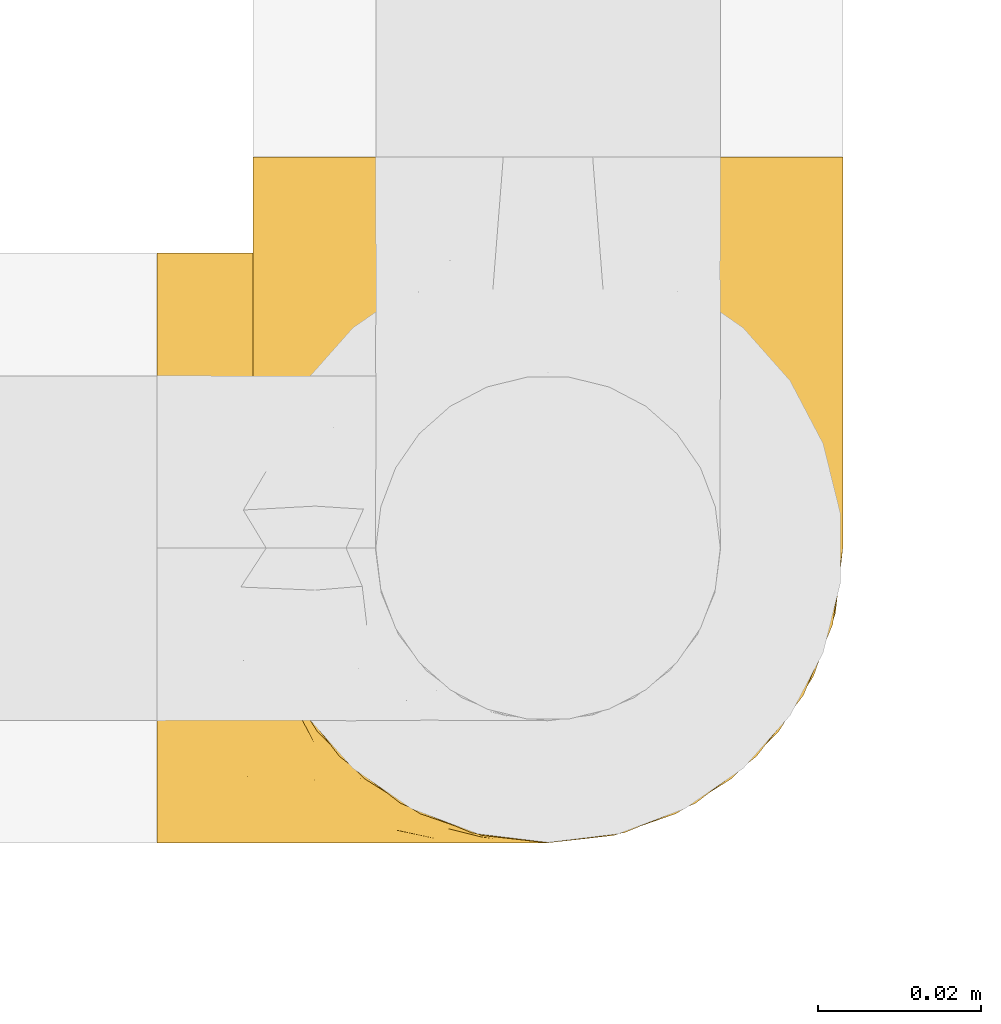
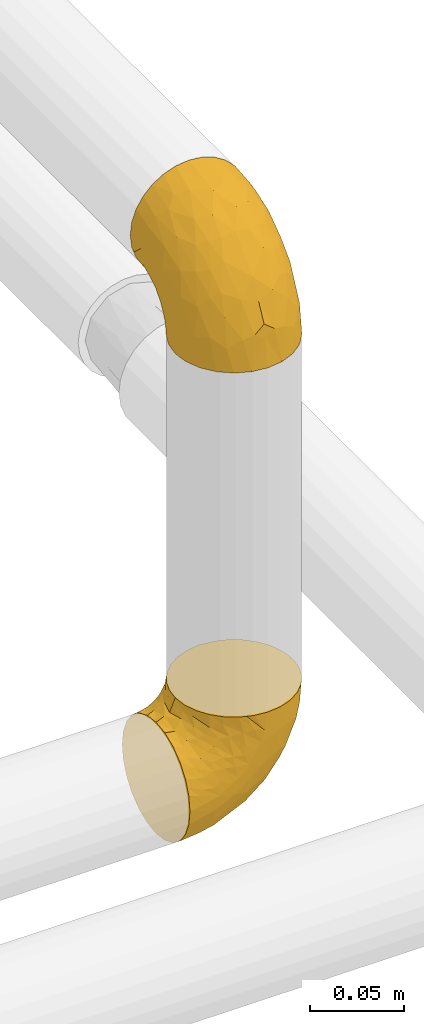
# One storey, part 23 of 39: 2 coverings.
"""IFC2X3 building model written with IfcOpenShell, lengths in millimetres."""

from ifc_helpers import new_model, entity, si_unit, converted_unit, derived_unit, direction, frame, origin, place, context, subcontext, project, spatial, faceted_brep, element, save


model = new_model("IFC2X3")

# Units and contexts
model_context = context("Model", 3, precision=0.01, world=origin(), true_north=direction((6.12303176911189e-17, 1.0)))
body_context = subcontext(model_context, "Body", "Model", "MODEL_VIEW")
ifc_project = project(units=[si_unit("LENGTHUNIT", "METRE", prefix="MILLI"), si_unit("AREAUNIT", "SQUARE_METRE"), si_unit("VOLUMEUNIT", "CUBIC_METRE"), converted_unit("PLANEANGLEUNIT", "DEGREE", entity("IfcRatioMeasure", 0.0174532925199433), si_unit("PLANEANGLEUNIT", "RADIAN"), dimensions=[0, 0, 0, 0, 0, 0, 0]), si_unit("MASSUNIT", "GRAM", prefix="KILO"), derived_unit("MASSDENSITYUNIT", [(si_unit("MASSUNIT", "GRAM", prefix="KILO"), 1), (si_unit("LENGTHUNIT", "METRE"), -3)]), derived_unit("MOMENTOFINERTIAUNIT", [(si_unit("LENGTHUNIT", "METRE"), 4)]), si_unit("TIMEUNIT", "SECOND"), si_unit("FREQUENCYUNIT", "HERTZ"), si_unit("THERMODYNAMICTEMPERATUREUNIT", "DEGREE_CELSIUS"), derived_unit("THERMALTRANSMITTANCEUNIT", [(si_unit("MASSUNIT", "GRAM", prefix="KILO"), 1), (si_unit("THERMODYNAMICTEMPERATUREUNIT", "KELVIN"), -1), (si_unit("TIMEUNIT", "SECOND"), -3)]), derived_unit("VOLUMETRICFLOWRATEUNIT", [(si_unit("LENGTHUNIT", "METRE"), 3), (si_unit("TIMEUNIT", "SECOND"), -1)]), derived_unit("MASSFLOWRATEUNIT", [(si_unit("MASSUNIT", "GRAM", prefix="KILO"), 1), (si_unit("TIMEUNIT", "SECOND"), -1)]), derived_unit("ROTATIONALFREQUENCYUNIT", [(si_unit("TIMEUNIT", "SECOND"), -1)]), si_unit("ELECTRICCURRENTUNIT", "AMPERE"), si_unit("ELECTRICVOLTAGEUNIT", "VOLT"), si_unit("POWERUNIT", "WATT"), si_unit("FORCEUNIT", "NEWTON", prefix="KILO"), si_unit("ILLUMINANCEUNIT", "LUX"), si_unit("LUMINOUSFLUXUNIT", "LUMEN"), si_unit("LUMINOUSINTENSITYUNIT", "CANDELA"), derived_unit("USERDEFINED", [(si_unit("MASSUNIT", "GRAM", prefix="KILO"), -1), (si_unit("LENGTHUNIT", "METRE"), -2), (si_unit("TIMEUNIT", "SECOND"), 3), (si_unit("LUMINOUSFLUXUNIT", "LUMEN"), 1)]), derived_unit("LINEARVELOCITYUNIT", [(si_unit("LENGTHUNIT", "METRE"), 1), (si_unit("TIMEUNIT", "SECOND"), -1)]), si_unit("PRESSUREUNIT", "PASCAL"), derived_unit("USERDEFINED", [(si_unit("LENGTHUNIT", "METRE"), -2), (si_unit("MASSUNIT", "GRAM", prefix="KILO"), 1), (si_unit("TIMEUNIT", "SECOND"), -2)]), derived_unit("LINEARFORCEUNIT", [(si_unit("MASSUNIT", "GRAM", prefix="KILO"), 1), (si_unit("LENGTHUNIT", "METRE"), 1), (si_unit("TIMEUNIT", "SECOND"), -2), (si_unit("LENGTHUNIT", "METRE"), -1)]), derived_unit("PLANARFORCEUNIT", [(si_unit("MASSUNIT", "GRAM", prefix="KILO"), 1), (si_unit("LENGTHUNIT", "METRE"), 1), (si_unit("TIMEUNIT", "SECOND"), -2), (si_unit("LENGTHUNIT", "METRE"), -2)])], contexts=[model_context])

# Site, building, storey
site_placement = place(None, origin())
site = spatial("IfcSite", under=ifc_project, at=site_placement, CompositionType="ELEMENT")
building_placement = place(site_placement, origin())
building = spatial("IfcBuilding", under=site, at=building_placement, CompositionType="ELEMENT")
storey_placement = place(building_placement, frame((0.0, 0.0, 24000.0)))
storey = spatial("IfcBuildingStorey", under=building, at=storey_placement, Name="07", CompositionType="ELEMENT", Elevation=24000.0)

# Coverings
covering_1_placement = place(storey_placement, frame((71565.42, 2837.56, 3042.2)))
element("IfcCovering", 1, at=covering_1_placement, inside=storey, Name=":ADSK_", ObjectType=":ADSK_", PredefinedType="INSULATION", context=body_context, shape_type="Brep", body=[
    faceted_brep([(49.6, 1.6, 85.8), (57.65, 2.5, 85.8), (65.31, 5.18, 85.8), (72.17, 9.5, 85.8), (77.9, 15.23, 85.8), (82.21, 22.09, 85.8), (84.89, 29.74, 85.8), (85.8, 37.8, 85.8), (84.89, 45.85, 85.8), (82.21, 53.51, 85.8), (77.89, 60.37, 85.8), (72.16, 66.1, 85.8), (65.3, 70.41, 85.8), (57.65, 73.09, 85.8), (49.6, 74.0, 85.8), (44.33, 73.4, 85.8), (41.54, 73.09, 85.8), (37.71, 71.75, 85.8), (33.88, 70.41, 85.8), (27.02, 66.09, 85.8), (21.29, 60.36, 85.8), (16.98, 53.5, 85.8), (14.3, 45.85, 85.8), (13.4, 37.8, 85.8), (14.3, 29.74, 85.8), (16.98, 22.08, 85.8), (21.3, 15.22, 85.8), (27.03, 9.49, 85.8), (33.89, 5.18, 85.8), (37.72, 3.84, 85.8), (41.54, 2.5, 85.8), (44.33, 2.19, 85.8), (1.6, 47.16, 72.76), (1.6, 55.9, 69.15), (1.6, 63.39, 63.39), (1.6, 66.27, 59.64), (1.6, 69.15, 55.9), (1.6, 70.95, 51.53), (1.6, 72.76, 47.16), (1.6, 73.3, 43.08), (1.6, 73.65, 40.44), (1.6, 74.0, 37.8), (1.6, 72.76, 28.43), (1.6, 69.15, 19.7), (1.6, 63.39, 12.2), (1.6, 55.9, 6.45), (1.6, 47.16, 2.83), (1.6, 37.8, 1.6), (1.6, 28.43, 2.83), (1.6, 19.7, 6.45), (1.6, 12.2, 12.2), (1.6, 6.45, 19.7), (1.6, 2.83, 28.43), (1.6, 1.6, 37.8), (1.6, 2.29, 43.08), (1.6, 2.83, 47.16), (1.6, 4.64, 51.53), (1.6, 6.45, 55.9), (1.6, 9.32, 59.64), (1.6, 12.2, 63.39), (1.6, 19.7, 69.15), (1.6, 28.43, 72.76), (1.6, 37.8, 74.0), (59.61, 25.48, 27.78), (60.4, 37.8, 26.99), (68.25, 29.15, 36.07), (27.61, 37.8, 5.72), (22.94, 31.57, 4.9), (19.4, 37.8, 4.42), (42.09, 28.0, 13.52), (33.53, 18.42, 14.0), (21.38, 25.21, 6.28), (16.47, 16.94, 9.64), (54.23, 2.22, 70.93), (38.23, 4.32, 36.05), (19.11, 5.43, 24.02), (36.76, 8.62, 25.93), (17.03, 2.37, 32.56), (19.96, 1.6, 41.45), (12.51, 1.6, 39.97), (9.78, 1.6, 39.42), (7.05, 1.6, 38.88), (21.71, 10.73, 16.62), (62.55, 4.66, 71.64), (75.89, 30.4, 47.83), (81.72, 27.02, 65.91), (74.04, 21.27, 51.38), (47.66, 2.65, 52.81), (45.94, 1.6, 67.43), (43.34, 1.6, 63.53), (40.74, 1.6, 59.64), (38.14, 1.6, 55.75), (35.54, 1.6, 51.85), (51.41, 6.87, 41.26), (30.21, 2.25, 38.98), (68.91, 8.31, 70.65), (74.03, 13.89, 65.64), (79.54, 19.66, 71.08), (82.98, 37.8, 67.99), (67.24, 22.57, 38.62), (55.48, 18.28, 28.73), (48.51, 1.6, 80.34), (47.42, 1.6, 74.88), (65.49, 10.73, 52.52), (64.99, 16.44, 41.68), (58.95, 5.54, 56.44), (45.7, 19.61, 19.89), (39.35, 37.8, 11.7), (53.72, 12.05, 34.04), (42.9, 14.19, 22.66), (81.67, 37.8, 59.78), (69.71, 37.8, 36.3), (75.69, 37.8, 48.04), (31.64, 1.6, 49.25), (27.75, 1.6, 46.65), (23.86, 1.6, 44.05), (51.09, 37.8, 17.68), (17.47, 4.69, 56.47), (18.36, 6.39, 60.92), (12.71, 9.76, 63.29), (7.84, 2.29, 45.31), (7.85, 8.52, 59.83), (6.14, 13.06, 64.71), (11.2, 23.29, 74.49), (14.99, 20.65, 76.83), (11.85, 29.05, 78.01), (23.69, 3.51, 56.9), (20.48, 2.42, 50.18), (14.49, 16.27, 71.99), (9.51, 19.23, 70.83), (6.6, 26.6, 73.18), (6.61, 17.24, 68.29), (26.46, 9.54, 80.74), (20.83, 14.03, 78.17), (28.69, 6.61, 73.83), (41.38, 2.33, 76.96), (7.16, 5.54, 54.72), (16.97, 2.2, 47.37), (12.64, 4.72, 54.39), (18.4, 14.42, 74.3), (35.97, 3.69, 75.54), (16.38, 10.4, 66.46), (11.31, 37.8, 80.75), (13.68, 29.55, 81.71), (15.78, 23.44, 81.69), (24.06, 9.02, 72.63), (9.94, 37.8, 77.45), (35.3, 2.25, 62.19), (36.41, 2.68, 67.73), (6.64, 37.8, 76.08), (10.52, 2.84, 48.26), (23.5, 5.45, 62.83), (29.62, 3.45, 62.31), (20.86, 9.31, 68.86), (29.66, 2.37, 56.53), (6.61, 58.36, 68.29), (6.59, 48.99, 73.17), (6.13, 62.53, 64.71), (48.51, 74.0, 80.34), (47.42, 74.0, 74.88), (13.67, 46.03, 81.71), (14.98, 54.93, 76.83), (15.78, 52.14, 81.69), (20.82, 61.55, 78.17), (12.51, 74.0, 39.97), (7.05, 74.0, 38.88), (4.32, 74.0, 38.34), (9.51, 56.36, 70.83), (11.19, 52.29, 74.49), (14.48, 59.3, 72.0), (10.19, 67.5, 59.87), (12.64, 70.87, 54.39), (7.16, 70.05, 54.72), (35.96, 71.9, 75.53), (10.52, 72.75, 48.26), (20.47, 73.17, 50.18), (17.47, 70.9, 56.47), (23.68, 72.08, 56.9), (16.97, 73.39, 47.37), (11.85, 46.54, 78.01), (7.84, 73.31, 45.31), (26.45, 66.04, 80.74), (18.39, 61.17, 74.3), (41.37, 73.26, 76.96), (29.62, 72.14, 62.32), (29.66, 73.22, 56.54), (23.5, 70.14, 62.83), (16.36, 65.18, 66.46), (35.87, 72.78, 67.82), (28.67, 68.97, 73.83), (45.94, 74.0, 67.43), (12.7, 65.83, 63.29), (24.04, 66.56, 72.63), (27.75, 74.0, 46.65), (30.95, 71.44, 67.39), (35.8, 73.42, 62.12), (43.34, 74.0, 63.53), (18.36, 69.2, 60.93), (19.96, 74.0, 41.45), (23.86, 74.0, 44.05), (20.85, 66.27, 68.85), (31.64, 74.0, 49.25), (38.14, 74.0, 55.75), (40.74, 74.0, 59.64), (35.54, 74.0, 51.85), (38.23, 71.27, 36.06), (17.03, 73.22, 32.56), (30.2, 73.34, 38.98), (64.98, 59.16, 41.69), (55.47, 57.32, 28.73), (53.71, 63.55, 34.05), (36.76, 66.97, 25.93), (51.4, 68.72, 41.26), (65.48, 64.87, 52.53), (47.66, 72.95, 52.81), (59.61, 50.11, 27.78), (45.69, 56.0, 19.9), (19.11, 70.16, 24.02), (22.94, 44.03, 4.9), (21.39, 50.38, 6.28), (58.94, 70.06, 56.45), (16.47, 58.65, 9.64), (21.71, 64.86, 16.62), (33.54, 57.17, 14.0), (74.04, 54.33, 51.38), (81.72, 48.58, 65.91), (75.89, 45.2, 47.82), (54.23, 73.37, 70.94), (74.02, 61.71, 65.64), (68.9, 67.29, 70.65), (42.09, 47.59, 13.52), (68.25, 46.45, 36.08), (67.24, 53.03, 38.62), (79.54, 55.95, 71.07), (42.91, 61.41, 22.68), (62.54, 70.93, 71.64)], [[[0, 1, 2, 3, 4, 5, 6, 7, 8, 9, 10, 11, 12, 13, 14, 15, 16, 17, 18, 19, 20, 21, 22, 23, 24, 25, 26, 27, 28, 29, 30, 31]], [[32, 33, 34, 35, 36, 37, 38, 39, 40, 41, 42, 43, 44, 45, 46, 47, 48, 49, 50, 51, 52, 53, 54, 55, 56, 57, 58, 59, 60, 61, 62]], [[63, 64, 65]], [[66, 67, 68]], [[69, 70, 71]], [[71, 70, 72]], [[73, 1, 0]], [[74, 75, 76]], [[49, 48, 71]], [[77, 78, 79, 80, 81, 53]], [[50, 82, 51]], [[72, 50, 49]], [[2, 1, 83]], [[84, 85, 86]], [[87, 88, 89, 90, 91, 92]], [[53, 52, 77]], [[93, 74, 76]], [[5, 85, 6]], [[94, 78, 77]], [[95, 3, 2]], [[95, 96, 3]], [[75, 51, 82]], [[85, 5, 97]], [[50, 72, 82]], [[97, 5, 4]], [[85, 98, 6]], [[94, 87, 92]], [[74, 77, 75]], [[99, 100, 63]], [[96, 4, 3]], [[73, 0, 101, 102, 88]], [[96, 103, 104]], [[48, 68, 67]], [[84, 99, 65]], [[105, 83, 73]], [[105, 95, 83]], [[100, 106, 63]], [[86, 96, 104]], [[97, 86, 85]], [[67, 107, 69]], [[100, 108, 109]], [[84, 110, 85]], [[93, 87, 74]], [[96, 95, 103]], [[69, 71, 67]], [[70, 69, 106]], [[4, 96, 97]], [[86, 97, 96]], [[83, 95, 2]], [[103, 95, 105]], [[93, 103, 105]], [[103, 108, 104]], [[75, 77, 52]], [[94, 77, 74]], [[51, 75, 52]], [[75, 82, 76]], [[109, 82, 70]], [[93, 76, 108]], [[88, 87, 73]], [[105, 73, 87]], [[84, 86, 99]], [[84, 111, 112, 110]], [[98, 85, 110]], [[98, 7, 6]], [[73, 83, 1]], [[71, 72, 49]], [[82, 72, 70]], [[87, 94, 74]], [[94, 92, 113, 114, 115, 78]], [[48, 47, 68]], [[48, 67, 71]], [[100, 104, 108]], [[99, 86, 104]], [[109, 108, 76]], [[100, 109, 106]], [[82, 109, 76]], [[106, 109, 70]], [[100, 99, 104]], [[99, 63, 65]], [[69, 116, 63]], [[111, 84, 65]], [[64, 63, 116]], [[64, 111, 65]], [[63, 106, 69]], [[103, 93, 108]], [[87, 93, 105]], [[107, 67, 66]], [[107, 116, 69]], [[117, 118, 119]], [[80, 120, 55]], [[121, 119, 122]], [[120, 56, 55]], [[123, 124, 125]], [[114, 126, 127]], [[101, 0, 31, 30, 102]], [[123, 128, 124]], [[129, 123, 130]], [[60, 122, 131]], [[132, 133, 134]], [[29, 28, 135]], [[131, 61, 60]], [[122, 60, 59]], [[136, 137, 138]], [[124, 128, 139]], [[132, 27, 26]], [[131, 130, 61]], [[140, 135, 28]], [[102, 29, 135]], [[119, 118, 141]], [[58, 136, 121]], [[140, 28, 27]], [[54, 53, 81, 80, 55]], [[23, 142, 143]], [[24, 144, 25]], [[25, 144, 133]], [[26, 25, 133]], [[134, 133, 145]], [[125, 142, 146]], [[124, 143, 125]], [[147, 90, 148]], [[124, 144, 143]], [[149, 125, 146]], [[150, 57, 56]], [[137, 78, 115]], [[130, 62, 61]], [[132, 140, 27]], [[151, 152, 153]], [[140, 134, 148]], [[148, 89, 140]], [[120, 78, 150]], [[115, 127, 137]], [[137, 136, 150]], [[78, 120, 80, 79]], [[150, 56, 120]], [[91, 154, 92]], [[127, 117, 138]], [[144, 24, 143]], [[133, 144, 124]], [[152, 91, 147]], [[145, 152, 134]], [[23, 143, 24]], [[142, 125, 143]], [[130, 125, 149]], [[128, 123, 129]], [[141, 129, 119]], [[124, 139, 133]], [[125, 130, 123]], [[62, 130, 149]], [[128, 153, 139]], [[145, 139, 153]], [[92, 154, 113]], [[127, 115, 114]], [[117, 127, 126]], [[118, 117, 126]], [[121, 117, 119]], [[138, 137, 127]], [[78, 137, 150]], [[151, 118, 126]], [[118, 151, 141]], [[153, 128, 141]], [[129, 141, 128]], [[102, 30, 29]], [[140, 88, 135]], [[88, 102, 135]], [[133, 132, 26]], [[140, 132, 134]], [[121, 122, 59]], [[131, 119, 129]], [[121, 59, 58]], [[121, 138, 117]], [[136, 58, 57]], [[150, 136, 57]], [[121, 136, 138]], [[119, 131, 122]], [[131, 129, 130]], [[139, 145, 133]], [[152, 145, 153]], [[89, 148, 90]], [[89, 88, 140]], [[147, 134, 152]], [[134, 147, 148]], [[126, 114, 113]], [[152, 154, 91]], [[91, 90, 147]], [[151, 153, 141]], [[154, 151, 126]], [[151, 154, 152]], [[113, 154, 126]], [[155, 32, 156]], [[33, 157, 34]], [[62, 149, 156]], [[15, 14, 158, 159, 16]], [[160, 23, 22]], [[161, 162, 163]], [[40, 39, 38, 164, 165, 166, 41]], [[167, 168, 169]], [[157, 170, 34]], [[171, 172, 170]], [[18, 173, 19]], [[174, 37, 36]], [[175, 176, 177]], [[178, 171, 175]], [[146, 179, 149]], [[168, 179, 161]], [[161, 160, 162]], [[162, 160, 22]], [[38, 37, 180]], [[20, 19, 181]], [[21, 20, 163]], [[161, 182, 169]], [[18, 183, 173]], [[184, 185, 186]], [[169, 187, 167]], [[188, 189, 173]], [[159, 190, 183]], [[17, 159, 183]], [[156, 179, 168]], [[191, 157, 155]], [[192, 163, 189]], [[21, 162, 22]], [[146, 142, 179]], [[181, 163, 20]], [[193, 175, 177]], [[178, 172, 171]], [[167, 156, 168]], [[184, 194, 195]], [[181, 173, 189]], [[173, 196, 188]], [[197, 186, 177]], [[198, 164, 180]], [[180, 164, 38]], [[199, 178, 175]], [[37, 174, 180]], [[198, 180, 174]], [[175, 193, 199]], [[177, 176, 197]], [[163, 162, 21]], [[160, 161, 179]], [[192, 184, 200]], [[194, 189, 188]], [[179, 142, 160]], [[23, 160, 142]], [[169, 168, 161]], [[155, 156, 167]], [[182, 161, 163]], [[200, 186, 187]], [[62, 156, 32]], [[179, 156, 149]], [[192, 182, 163]], [[200, 169, 182]], [[176, 175, 171]], [[174, 178, 198]], [[185, 201, 177]], [[170, 176, 171]], [[197, 176, 191]], [[198, 178, 199]], [[178, 174, 172]], [[187, 197, 191]], [[197, 187, 186]], [[167, 187, 191]], [[169, 200, 187]], [[173, 183, 190]], [[17, 16, 159]], [[173, 181, 19]], [[163, 181, 189]], [[155, 157, 33]], [[170, 157, 191]], [[176, 170, 191]], [[35, 170, 172]], [[35, 172, 36]], [[34, 170, 35]], [[174, 36, 172]], [[32, 155, 33]], [[191, 155, 167]], [[192, 189, 194]], [[182, 192, 200]], [[185, 184, 202]], [[183, 18, 17]], [[196, 173, 190]], [[196, 203, 188]], [[201, 193, 177]], [[200, 184, 186]], [[188, 195, 194]], [[204, 185, 202]], [[188, 203, 195]], [[192, 194, 184]], [[203, 202, 195]], [[184, 195, 202]], [[201, 185, 204]], [[186, 185, 177]], [[205, 206, 207]], [[208, 209, 210]], [[210, 211, 212]], [[210, 213, 208]], [[214, 204, 202, 203, 196, 190]], [[206, 41, 166, 165, 164, 198]], [[215, 216, 209]], [[206, 217, 42]], [[218, 46, 219]], [[207, 214, 205]], [[212, 214, 220]], [[221, 219, 45]], [[45, 219, 46]], [[221, 222, 223]], [[224, 225, 226]], [[222, 44, 43]], [[222, 217, 211]], [[220, 214, 227]], [[227, 190, 159, 158, 14]], [[217, 43, 42]], [[14, 13, 227]], [[225, 9, 8]], [[10, 228, 11]], [[11, 229, 12]], [[208, 213, 228]], [[228, 229, 11]], [[230, 219, 223]], [[231, 232, 226]], [[231, 64, 215]], [[225, 233, 9]], [[229, 213, 220]], [[233, 10, 9]], [[110, 225, 98]], [[41, 206, 42]], [[222, 211, 234]], [[224, 228, 233]], [[225, 8, 98]], [[221, 45, 44]], [[226, 110, 112, 111]], [[12, 229, 235]], [[46, 218, 68]], [[230, 107, 218]], [[223, 234, 216]], [[107, 66, 218]], [[224, 233, 225]], [[228, 10, 233]], [[213, 229, 228]], [[235, 229, 220]], [[208, 228, 224]], [[212, 213, 210]], [[207, 206, 198]], [[205, 211, 217]], [[205, 217, 206]], [[43, 217, 222]], [[212, 211, 205]], [[210, 209, 234]], [[227, 13, 235]], [[214, 190, 227]], [[110, 226, 225]], [[232, 231, 215]], [[8, 7, 98]], [[227, 235, 220]], [[13, 12, 235]], [[222, 221, 44]], [[219, 221, 223]], [[207, 198, 199, 193, 201, 204]], [[214, 207, 204]], [[68, 218, 66]], [[68, 47, 46]], [[230, 218, 219]], [[224, 232, 208]], [[208, 232, 209]], [[216, 215, 230]], [[210, 234, 211]], [[216, 234, 209]], [[222, 234, 223]], [[226, 232, 224]], [[209, 232, 215]], [[226, 111, 231]], [[64, 116, 215]], [[231, 111, 64]], [[116, 230, 215]], [[230, 223, 216]], [[214, 212, 205]], [[213, 212, 220]], [[230, 116, 107]]]),
])
covering_2_placement = place(storey_placement, frame((71577.22, 2837.56, 3350.4)))
element("IfcCovering", 2, at=covering_2_placement, inside=storey, Name=":ADSK_", ObjectType=":ADSK_", PredefinedType="INSULATION", context=body_context, shape_type="Brep", body=[
    faceted_brep([(1.6, 85.8, 49.6), (2.5, 85.8, 57.65), (5.18, 85.8, 65.31), (9.5, 85.8, 72.17), (15.23, 85.8, 77.9), (22.09, 85.8, 82.21), (29.74, 85.8, 84.89), (37.8, 85.8, 85.8), (45.85, 85.8, 84.89), (53.51, 85.8, 82.21), (60.37, 85.8, 77.89), (66.1, 85.8, 72.16), (70.41, 85.8, 65.3), (73.09, 85.8, 57.65), (74.0, 85.8, 49.6), (73.4, 85.8, 44.33), (73.09, 85.8, 41.54), (71.75, 85.8, 37.71), (70.41, 85.8, 33.88), (66.09, 85.8, 27.02), (60.36, 85.8, 21.29), (53.5, 85.8, 16.98), (45.85, 85.8, 14.3), (37.8, 85.8, 13.4), (29.74, 85.8, 14.3), (22.08, 85.8, 16.98), (15.22, 85.8, 21.3), (9.49, 85.8, 27.03), (5.18, 85.8, 33.89), (3.84, 85.8, 37.72), (2.5, 85.8, 41.54), (2.19, 85.8, 44.33), (47.16, 72.76, 1.6), (55.9, 69.15, 1.6), (63.39, 63.39, 1.6), (66.27, 59.64, 1.6), (69.15, 55.9, 1.6), (70.95, 51.53, 1.6), (72.76, 47.16, 1.6), (73.3, 43.08, 1.6), (73.65, 40.44, 1.6), (74.0, 37.8, 1.6), (72.76, 28.43, 1.6), (69.15, 19.7, 1.6), (63.39, 12.2, 1.6), (55.9, 6.45, 1.6), (47.16, 2.83, 1.6), (37.8, 1.6, 1.6), (28.43, 2.83, 1.6), (19.7, 6.45, 1.6), (12.2, 12.2, 1.6), (6.45, 19.7, 1.6), (2.83, 28.43, 1.6), (1.6, 37.8, 1.6), (2.29, 43.08, 1.6), (2.83, 47.16, 1.6), (4.64, 51.53, 1.6), (6.45, 55.9, 1.6), (9.32, 59.64, 1.6), (12.2, 63.39, 1.6), (19.7, 69.15, 1.6), (28.43, 72.76, 1.6), (37.8, 74.0, 1.6), (25.48, 27.78, 59.61), (37.8, 26.99, 60.4), (29.15, 36.07, 68.25), (37.8, 5.72, 27.61), (31.57, 4.9, 22.94), (37.8, 4.42, 19.4), (28.0, 13.52, 42.09), (18.42, 14.0, 33.53), (25.21, 6.28, 21.38), (16.94, 9.64, 16.47), (2.22, 70.93, 54.23), (4.32, 36.05, 38.23), (5.43, 24.02, 19.11), (8.62, 25.93, 36.76), (2.37, 32.56, 17.03), (1.6, 41.45, 19.96), (1.6, 39.97, 12.51), (1.6, 39.42, 9.78), (1.6, 38.88, 7.05), (10.73, 16.62, 21.71), (4.66, 71.64, 62.55), (30.4, 47.83, 75.89), (27.02, 65.91, 81.72), (21.27, 51.38, 74.04), (2.65, 52.81, 47.66), (1.6, 67.43, 45.94), (1.6, 63.53, 43.34), (1.6, 59.64, 40.74), (1.6, 55.75, 38.14), (1.6, 51.85, 35.54), (6.87, 41.26, 51.41), (2.25, 38.98, 30.21), (8.31, 70.65, 68.91), (13.89, 65.64, 74.03), (19.66, 71.08, 79.54), (37.8, 67.99, 82.98), (22.57, 38.62, 67.24), (18.28, 28.73, 55.48), (1.6, 80.34, 48.51), (1.6, 74.88, 47.42), (10.73, 52.52, 65.49), (16.44, 41.68, 64.99), (5.54, 56.44, 58.95), (19.61, 19.89, 45.7), (37.8, 11.7, 39.35), (12.05, 34.04, 53.72), (14.19, 22.66, 42.9), (37.8, 59.78, 81.67), (37.8, 36.3, 69.71), (37.8, 48.04, 75.69), (1.6, 49.25, 31.64), (1.6, 46.65, 27.75), (1.6, 44.05, 23.86), (37.8, 17.68, 51.09), (4.69, 56.47, 17.47), (6.39, 60.92, 18.36), (9.76, 63.29, 12.71), (2.29, 45.31, 7.84), (8.52, 59.83, 7.85), (13.06, 64.71, 6.14), (23.29, 74.49, 11.2), (20.65, 76.83, 14.99), (29.05, 78.01, 11.85), (3.51, 56.9, 23.69), (2.42, 50.18, 20.48), (16.27, 71.99, 14.49), (19.23, 70.83, 9.51), (26.6, 73.18, 6.6), (17.24, 68.29, 6.61), (9.54, 80.74, 26.46), (14.03, 78.17, 20.83), (6.61, 73.83, 28.69), (2.33, 76.96, 41.38), (5.54, 54.72, 7.16), (2.2, 47.37, 16.97), (4.72, 54.39, 12.64), (14.42, 74.3, 18.4), (3.69, 75.54, 35.97), (10.4, 66.46, 16.38), (37.8, 80.75, 11.31), (29.55, 81.71, 13.68), (23.44, 81.69, 15.78), (9.02, 72.63, 24.06), (37.8, 77.45, 9.94), (2.25, 62.19, 35.3), (2.68, 67.73, 36.41), (37.8, 76.08, 6.64), (2.84, 48.26, 10.52), (5.45, 62.83, 23.5), (3.45, 62.31, 29.62), (9.31, 68.86, 20.86), (2.37, 56.53, 29.66), (58.36, 68.29, 6.61), (48.99, 73.17, 6.59), (62.53, 64.71, 6.13), (74.0, 80.34, 48.51), (74.0, 74.88, 47.42), (46.03, 81.71, 13.67), (54.93, 76.83, 14.98), (52.14, 81.69, 15.78), (61.55, 78.17, 20.82), (74.0, 39.97, 12.51), (74.0, 38.88, 7.05), (74.0, 38.34, 4.32), (56.36, 70.83, 9.51), (52.29, 74.49, 11.19), (59.3, 72.0, 14.48), (67.5, 59.87, 10.19), (70.87, 54.39, 12.64), (70.05, 54.72, 7.16), (71.9, 75.53, 35.96), (72.75, 48.26, 10.52), (73.17, 50.18, 20.47), (70.9, 56.47, 17.47), (72.08, 56.9, 23.68), (73.39, 47.37, 16.97), (46.54, 78.01, 11.85), (73.31, 45.31, 7.84), (66.04, 80.74, 26.45), (61.17, 74.3, 18.39), (73.26, 76.96, 41.37), (72.14, 62.32, 29.62), (73.22, 56.54, 29.66), (70.14, 62.83, 23.5), (65.18, 66.46, 16.36), (72.78, 67.82, 35.87), (68.97, 73.83, 28.67), (74.0, 67.43, 45.94), (65.83, 63.29, 12.7), (66.56, 72.63, 24.04), (74.0, 55.75, 38.14), (71.44, 67.39, 30.95), (73.42, 62.12, 35.8), (74.0, 63.53, 43.34), (74.0, 46.65, 27.75), (74.0, 49.25, 31.64), (74.0, 41.45, 19.96), (74.0, 44.05, 23.86), (69.2, 60.93, 18.36), (66.27, 68.85, 20.85), (74.0, 59.64, 40.74), (74.0, 51.85, 35.54), (71.27, 36.06, 38.23), (73.22, 32.56, 17.03), (73.34, 38.98, 30.2), (59.16, 41.69, 64.98), (57.32, 28.73, 55.47), (63.55, 34.05, 53.71), (66.97, 25.93, 36.76), (68.72, 41.26, 51.4), (64.87, 52.53, 65.48), (72.95, 52.81, 47.66), (50.11, 27.78, 59.61), (56.0, 19.9, 45.69), (70.16, 24.02, 19.11), (44.03, 4.9, 22.94), (50.38, 6.28, 21.39), (70.06, 56.45, 58.94), (58.65, 9.64, 16.47), (64.86, 16.62, 21.71), (57.17, 14.0, 33.54), (54.33, 51.38, 74.04), (48.58, 65.91, 81.72), (45.2, 47.82, 75.89), (73.37, 70.94, 54.23), (61.71, 65.64, 74.02), (67.29, 70.65, 68.9), (47.59, 13.52, 42.09), (46.45, 36.08, 68.25), (53.03, 38.62, 67.24), (55.95, 71.07, 79.54), (61.41, 22.68, 42.91), (70.93, 71.64, 62.54)], [[[0, 1, 2, 3, 4, 5, 6, 7, 8, 9, 10, 11, 12, 13, 14, 15, 16, 17, 18, 19, 20, 21, 22, 23, 24, 25, 26, 27, 28, 29, 30, 31]], [[32, 33, 34, 35, 36, 37, 38, 39, 40, 41, 42, 43, 44, 45, 46, 47, 48, 49, 50, 51, 52, 53, 54, 55, 56, 57, 58, 59, 60, 61, 62]], [[63, 64, 65]], [[66, 67, 68]], [[69, 70, 71]], [[71, 70, 72]], [[73, 1, 0]], [[74, 75, 76]], [[49, 48, 71]], [[77, 78, 79, 80, 81, 53]], [[50, 82, 51]], [[72, 50, 49]], [[2, 1, 83]], [[84, 85, 86]], [[87, 88, 89, 90, 91, 92]], [[53, 52, 77]], [[93, 74, 76]], [[5, 85, 6]], [[94, 78, 77]], [[95, 3, 2]], [[95, 96, 3]], [[75, 51, 82]], [[85, 5, 97]], [[50, 72, 82]], [[97, 5, 4]], [[85, 98, 6]], [[94, 87, 92]], [[74, 77, 75]], [[99, 100, 63]], [[96, 4, 3]], [[73, 0, 101, 102, 88]], [[96, 103, 104]], [[48, 68, 67]], [[84, 99, 65]], [[105, 83, 73]], [[105, 95, 83]], [[100, 106, 63]], [[86, 96, 104]], [[97, 86, 85]], [[67, 107, 69]], [[100, 108, 109]], [[84, 110, 85]], [[93, 87, 74]], [[96, 95, 103]], [[69, 71, 67]], [[70, 69, 106]], [[4, 96, 97]], [[86, 97, 96]], [[83, 95, 2]], [[103, 95, 105]], [[93, 103, 105]], [[103, 108, 104]], [[75, 77, 52]], [[94, 77, 74]], [[51, 75, 52]], [[75, 82, 76]], [[109, 82, 70]], [[93, 76, 108]], [[88, 87, 73]], [[105, 73, 87]], [[84, 86, 99]], [[84, 111, 112, 110]], [[98, 85, 110]], [[98, 7, 6]], [[73, 83, 1]], [[71, 72, 49]], [[82, 72, 70]], [[87, 94, 74]], [[94, 92, 113, 114, 115, 78]], [[48, 47, 68]], [[48, 67, 71]], [[100, 104, 108]], [[99, 86, 104]], [[109, 108, 76]], [[100, 109, 106]], [[82, 109, 76]], [[106, 109, 70]], [[100, 99, 104]], [[99, 63, 65]], [[69, 116, 63]], [[111, 84, 65]], [[64, 63, 116]], [[64, 111, 65]], [[63, 106, 69]], [[103, 93, 108]], [[87, 93, 105]], [[107, 67, 66]], [[107, 116, 69]], [[117, 118, 119]], [[80, 120, 55]], [[121, 119, 122]], [[120, 56, 55]], [[123, 124, 125]], [[114, 126, 127]], [[101, 0, 31, 30, 102]], [[123, 128, 124]], [[129, 123, 130]], [[60, 122, 131]], [[132, 133, 134]], [[29, 28, 135]], [[131, 61, 60]], [[122, 60, 59]], [[136, 137, 138]], [[124, 128, 139]], [[132, 27, 26]], [[131, 130, 61]], [[140, 135, 28]], [[102, 29, 135]], [[119, 118, 141]], [[58, 136, 121]], [[140, 28, 27]], [[54, 53, 81, 80, 55]], [[23, 142, 143]], [[24, 144, 25]], [[25, 144, 133]], [[26, 25, 133]], [[134, 133, 145]], [[125, 142, 146]], [[124, 143, 125]], [[147, 90, 148]], [[124, 144, 143]], [[149, 125, 146]], [[150, 57, 56]], [[137, 78, 115]], [[130, 62, 61]], [[132, 140, 27]], [[151, 152, 153]], [[140, 134, 148]], [[148, 89, 140]], [[120, 78, 150]], [[115, 127, 137]], [[137, 136, 150]], [[78, 120, 80, 79]], [[150, 56, 120]], [[152, 151, 154]], [[127, 117, 138]], [[144, 24, 143]], [[133, 144, 124]], [[152, 91, 147]], [[145, 152, 134]], [[23, 143, 24]], [[142, 125, 143]], [[130, 125, 149]], [[128, 123, 129]], [[141, 129, 119]], [[124, 139, 133]], [[125, 130, 123]], [[62, 130, 149]], [[128, 153, 139]], [[145, 139, 153]], [[92, 154, 113]], [[127, 115, 114]], [[117, 127, 126]], [[118, 117, 126]], [[121, 117, 119]], [[138, 137, 127]], [[78, 137, 150]], [[151, 118, 126]], [[118, 151, 141]], [[153, 128, 141]], [[129, 141, 128]], [[102, 30, 29]], [[140, 88, 135]], [[88, 102, 135]], [[133, 132, 26]], [[140, 132, 134]], [[121, 122, 59]], [[131, 119, 129]], [[121, 59, 58]], [[121, 138, 117]], [[136, 58, 57]], [[150, 136, 57]], [[121, 136, 138]], [[119, 131, 122]], [[131, 129, 130]], [[139, 145, 133]], [[152, 145, 153]], [[89, 148, 90]], [[89, 88, 140]], [[147, 134, 152]], [[134, 147, 148]], [[126, 114, 113]], [[152, 154, 91]], [[91, 90, 147]], [[151, 153, 141]], [[154, 151, 126]], [[113, 154, 126]], [[91, 154, 92]], [[155, 32, 156]], [[33, 157, 34]], [[62, 149, 156]], [[15, 14, 158, 159, 16]], [[160, 23, 22]], [[161, 162, 163]], [[40, 39, 38, 164, 165, 166, 41]], [[167, 168, 169]], [[157, 170, 34]], [[171, 172, 170]], [[18, 173, 19]], [[174, 37, 36]], [[175, 176, 177]], [[178, 171, 175]], [[146, 179, 149]], [[168, 179, 161]], [[161, 160, 162]], [[162, 160, 22]], [[38, 37, 180]], [[20, 19, 181]], [[21, 20, 163]], [[161, 182, 169]], [[18, 183, 173]], [[184, 185, 186]], [[169, 187, 167]], [[188, 189, 173]], [[159, 190, 183]], [[17, 159, 183]], [[156, 179, 168]], [[191, 157, 155]], [[192, 163, 189]], [[21, 162, 22]], [[146, 142, 179]], [[181, 163, 20]], [[185, 184, 193]], [[178, 172, 171]], [[167, 156, 168]], [[184, 194, 195]], [[181, 173, 189]], [[173, 196, 188]], [[197, 177, 198]], [[199, 164, 180]], [[180, 164, 38]], [[200, 178, 175]], [[37, 174, 180]], [[199, 180, 174]], [[175, 197, 200]], [[177, 176, 201]], [[163, 162, 21]], [[160, 161, 179]], [[192, 184, 202]], [[194, 189, 188]], [[179, 142, 160]], [[23, 160, 142]], [[169, 168, 161]], [[155, 156, 167]], [[182, 161, 163]], [[202, 186, 187]], [[62, 156, 32]], [[179, 156, 149]], [[192, 182, 163]], [[202, 169, 182]], [[176, 175, 171]], [[174, 178, 199]], [[197, 175, 177]], [[170, 176, 171]], [[201, 176, 191]], [[199, 178, 200]], [[178, 174, 172]], [[187, 201, 191]], [[201, 187, 186]], [[167, 187, 191]], [[169, 202, 187]], [[173, 183, 190]], [[17, 16, 159]], [[173, 181, 19]], [[163, 181, 189]], [[155, 157, 33]], [[170, 157, 191]], [[176, 170, 191]], [[35, 170, 172]], [[35, 172, 36]], [[34, 170, 35]], [[174, 36, 172]], [[32, 155, 33]], [[191, 155, 167]], [[192, 189, 194]], [[182, 192, 202]], [[185, 198, 177]], [[183, 18, 17]], [[196, 173, 190]], [[196, 203, 188]], [[201, 186, 177]], [[202, 184, 186]], [[188, 195, 194]], [[204, 185, 193]], [[188, 203, 195]], [[192, 194, 184]], [[203, 193, 195]], [[184, 195, 193]], [[198, 185, 204]], [[186, 185, 177]], [[205, 206, 207]], [[208, 209, 210]], [[210, 211, 212]], [[210, 213, 208]], [[214, 204, 193, 203, 196, 190]], [[206, 41, 166, 165, 164, 199]], [[215, 216, 209]], [[206, 217, 42]], [[218, 46, 219]], [[207, 214, 205]], [[212, 214, 220]], [[221, 219, 45]], [[45, 219, 46]], [[221, 222, 223]], [[224, 225, 226]], [[222, 44, 43]], [[222, 217, 211]], [[220, 214, 227]], [[227, 190, 159, 158, 14]], [[217, 43, 42]], [[14, 13, 227]], [[225, 9, 8]], [[10, 228, 11]], [[11, 229, 12]], [[208, 213, 228]], [[228, 229, 11]], [[230, 219, 223]], [[231, 232, 226]], [[231, 64, 215]], [[225, 233, 9]], [[229, 213, 220]], [[233, 10, 9]], [[110, 225, 98]], [[41, 206, 42]], [[222, 211, 234]], [[224, 228, 233]], [[225, 8, 98]], [[221, 45, 44]], [[226, 110, 112, 111]], [[12, 229, 235]], [[46, 218, 68]], [[230, 107, 218]], [[223, 234, 216]], [[107, 66, 218]], [[224, 233, 225]], [[228, 10, 233]], [[213, 229, 228]], [[235, 229, 220]], [[208, 228, 224]], [[212, 213, 210]], [[207, 206, 199]], [[205, 211, 217]], [[205, 217, 206]], [[43, 217, 222]], [[212, 211, 205]], [[210, 209, 234]], [[227, 13, 235]], [[214, 190, 227]], [[110, 226, 225]], [[232, 231, 215]], [[8, 7, 98]], [[227, 235, 220]], [[13, 12, 235]], [[222, 221, 44]], [[219, 221, 223]], [[207, 199, 200, 197, 198, 204]], [[214, 207, 204]], [[68, 218, 66]], [[68, 47, 46]], [[230, 218, 219]], [[224, 232, 208]], [[208, 232, 209]], [[216, 215, 230]], [[210, 234, 211]], [[216, 234, 209]], [[222, 234, 223]], [[226, 232, 224]], [[209, 232, 215]], [[226, 111, 231]], [[64, 116, 215]], [[231, 111, 64]], [[116, 230, 215]], [[230, 223, 216]], [[214, 212, 205]], [[213, 212, 220]], [[230, 116, 107]]]),
])

save(model, "model.ifc")
